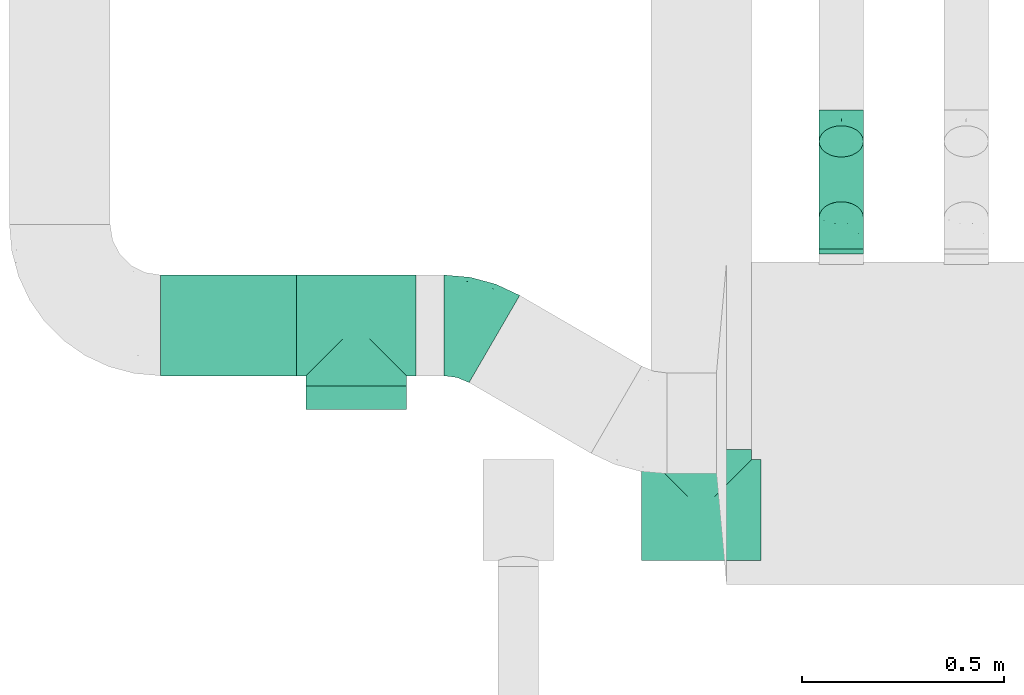
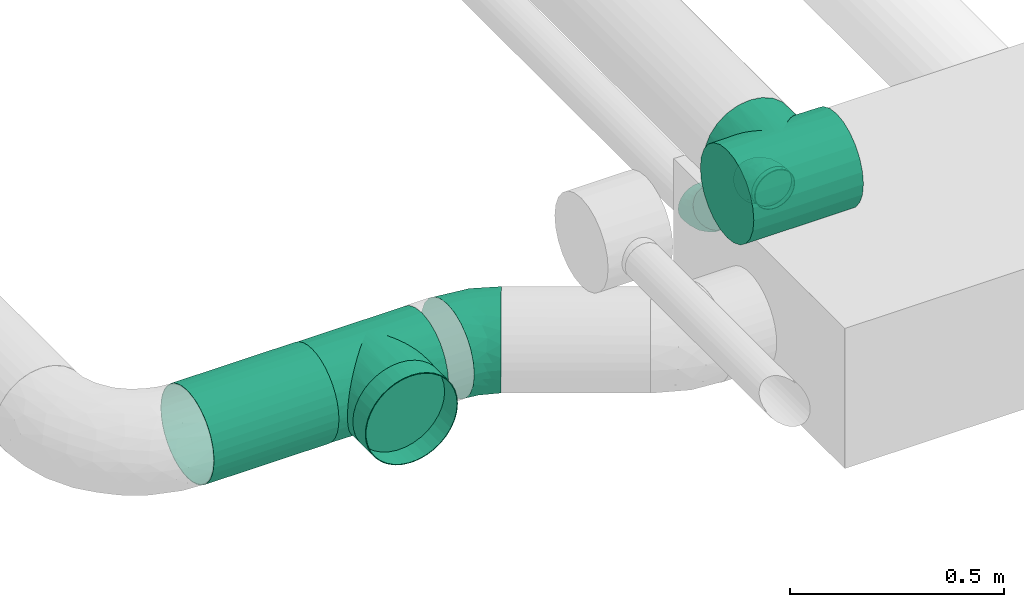
# One storey, part 18 of 91: 5 flow fittings, 4 flow segments.
"""IFC2X3 building model written with IfcOpenShell, lengths in millimetres."""

from ifc_helpers import new_model, entity, si_unit, converted_unit, derived_unit, direction, frame, origin_with_axes, origin_2d_with_axis, place, context, subcontext, project, spatial, hollow_circle, extrude, open_shell, surface_model, source, transform, mapped, material, layer, layer_set, layer_usage, type_object, element, save


model = new_model("IFC2X3")

# Units and contexts
model_context = context("Model", 3, precision=1e-05, world=origin_with_axes(), true_north=direction((0.0, 1.0)))
body_context = subcontext(model_context, "Body", "Model", "MODEL_VIEW")
ifc_project = project(units=[si_unit("AREAUNIT", "SQUARE_METRE"), si_unit("VOLUMEUNIT", "CUBIC_METRE", prefix="DECI"), si_unit("TIMEUNIT", "SECOND"), si_unit("THERMODYNAMICTEMPERATUREUNIT", "DEGREE_CELSIUS"), si_unit("PRESSUREUNIT", "PASCAL"), si_unit("MASSUNIT", "GRAM", prefix="KILO"), si_unit("LENGTHUNIT", "METRE", prefix="MILLI"), si_unit("POWERUNIT", "WATT"), si_unit("ELECTRICCURRENTUNIT", "AMPERE"), si_unit("ELECTRICVOLTAGEUNIT", "VOLT"), derived_unit("VOLUMETRICFLOWRATEUNIT", [(si_unit("VOLUMEUNIT", "CUBIC_METRE", prefix="DECI"), 1), (si_unit("TIMEUNIT", "SECOND"), -1)]), derived_unit("LINEARVELOCITYUNIT", [(si_unit("LENGTHUNIT", "METRE"), 1), (si_unit("TIMEUNIT", "SECOND"), -1)]), derived_unit("MASSDENSITYUNIT", [(si_unit("MASSUNIT", "GRAM", prefix="KILO"), 1), (si_unit("VOLUMEUNIT", "CUBIC_METRE"), -1)]), converted_unit("PLANEANGLEUNIT", "DEGREE", entity("IfcRatioMeasure", 0.01745), si_unit("PLANEANGLEUNIT", "RADIAN"), dimensions=[0, 0, 0, 0, 0, 0, 0])], contexts=[model_context])

# Site, building, storey
site_placement = place(None, origin_with_axes())
site = spatial("IfcSite", under=ifc_project, at=site_placement, CompositionType="ELEMENT")
building_placement = place(site_placement, origin_with_axes())
building = spatial("IfcBuilding", under=site, at=building_placement, Name="mc-building", CompositionType="ELEMENT")
storey_placement = place(building_placement, frame((0.0, 0.0, 8700.0), z_axis=(0.0, 0.0, 1.0), x_axis=(1.0, 0.0, 0.0)))
storey = spatial("IfcBuildingStorey", under=building, at=storey_placement, CompositionType="ELEMENT", Elevation=8700.0)

# Flow fittings
duct_fitting_type_1 = type_object("IfcDuctFittingType", PredefinedType="JUNCTION")
shared_shape_1 = source(origin_with_axes(), body_context, "Body", "SurfaceModel", [
    surface_model("IfcShellBasedSurfaceModel", [(0.0, -150.0, -125.0), (32.35238, -150.0, -120.74073), (-32.35238, -150.0, -120.74073), (-120.74073, -150.0, 32.35238), (-62.5, -150.0, -108.25318), (-88.38835, -150.0, -88.38835), (-108.25318, -150.0, -62.5), (125.0, -150.0, 0.0), (120.74073, -150.0, 32.35238), (88.38835, -150.0, -88.38835), (62.5, -150.0, -108.25318), (120.74073, -150.0, -32.35238), (108.25318, -150.0, -62.5), (-120.74073, -150.0, -32.35238), (-108.25318, -150.0, 62.5), (-88.38835, -150.0, 88.38835), (-62.5, -150.0, 108.25318), (-32.35238, -150.0, 120.74073), (0.0, -150.0, 125.0), (108.25318, -150.0, 62.5), (88.38835, -150.0, 88.38835), (32.35238, -150.0, 120.74073), (62.5, -150.0, 108.25318), (-125.0, -150.0, 0.0), (0.0, 0.0, 125.0), (-11.24036, -11.24036, 124.49359), (0.0, -97.5961, 125.0), (-33.53651, -33.53651, 120.4172), (-44.49198, -44.49198, 116.8138), (-22.43518, -22.43518, 122.97017), (-55.24206, -55.24206, 112.13079), (-65.71683, -65.71683, 106.33107), (-75.83315, -75.83315, 99.36968), (-102.85623, -102.85623, 71.03235), (-98.32076, -150.0, 75.44417), (-94.54916, -94.54916, 81.76463), (-85.4881, -85.4881, 91.19641), (-116.36385, -116.36385, 45.65581), (-114.49695, -150.0, 47.42619), (-121.04637, -121.04637, 31.18936), (-110.2104, -110.2104, 58.98025), (-123.99275, -123.99275, 15.83659), (-125.0, -125.0, 0.0), (-122.87036, -150.0, 16.17619), (-121.04637, -121.04637, -31.18936), (-116.36385, -116.36385, -45.65581), (-122.87036, -150.0, -16.17619), (-123.99275, -123.99275, -15.83659), (-11.24036, -11.24036, -124.49359), (0.0, 0.0, -125.0), (0.0, -97.5961, -125.0), (-94.54916, -94.54916, -81.76463), (-98.32076, -150.0, -75.44417), (-110.2104, -110.2104, -58.98025), (-102.85623, -102.85623, -71.03235), (-114.49695, -150.0, -47.42619), (-85.4881, -85.4881, -91.19641), (-44.49198, -44.49198, -116.8138), (-33.53651, -33.53651, -120.4172), (-55.24206, -55.24206, -112.13079), (-22.43518, -22.43518, -122.97017), (-75.83315, -75.83315, -99.36968), (-65.71683, -65.71683, -106.33107), (11.24036, -11.24036, -124.49359), (0.0, -97.59611, -125.0), (33.53651, -33.53651, -120.4172), (44.49198, -44.49198, -116.8138), (22.43518, -22.43518, -122.97017), (55.24206, -55.24206, -112.13079), (65.71683, -65.71683, -106.33107), (75.83315, -75.83315, -99.36968), (102.85623, -102.85623, -71.03235), (98.32076, -150.0, -75.44417), (94.54916, -94.54916, -81.76463), (85.4881, -85.4881, -91.19641), (116.36385, -116.36385, -45.65581), (114.49695, -150.0, -47.42619), (121.04637, -121.04637, -31.18936), (110.2104, -110.2104, -58.98025), (123.99275, -123.99275, -15.83659), (125.0, -125.0, 0.0), (122.87036, -150.0, -16.17619), (121.04637, -121.04637, 31.18936), (116.36385, -116.36385, 45.65581), (122.87036, -150.0, 16.17619), (123.99275, -123.99275, 15.83659), (11.24036, -11.24036, 124.49359), (94.54916, -94.54916, 81.76463), (98.32076, -150.0, 75.44417), (110.2104, -110.2104, 58.98025), (102.85623, -102.85623, 71.03235), (114.49695, -150.0, 47.42619), (85.4881, -85.4881, 91.19641), (44.49198, -44.49198, 116.8138), (33.53651, -33.53651, 120.4172), (55.24206, -55.24206, 112.13079), (22.43518, -22.43518, 122.97017), (75.83315, -75.83315, 99.36968), (65.71683, -65.71683, 106.33107), (-148.0, 0.0, -125.0), (-148.0, -32.35238, -120.74073), (-148.0, 32.35238, -120.74073), (-148.0, 120.74073, 32.35238), (-148.0, 62.5, -108.25318), (-148.0, 88.38835, -88.38835), (-148.0, 108.25318, -62.5), (-148.0, -125.0, 0.0), (-148.0, -120.74073, 32.35238), (-148.0, -88.38835, -88.38835), (-148.0, -62.5, -108.25318), (-148.0, -120.74073, -32.35238), (-148.0, -108.25318, -62.5), (-148.0, 120.74073, -32.35238), (-148.0, 108.25318, 62.5), (-148.0, 62.5, 108.25318), (-148.0, 32.35238, 120.74073), (-148.0, 88.38835, 88.38835), (-148.0, 0.0, 125.0), (-148.0, -108.25318, 62.5), (-148.0, -88.38835, 88.38835), (-148.0, -32.35238, 120.74073), (-148.0, -62.5, 108.25318), (-148.0, 125.0, 0.0), (148.0, 32.35238, -120.74073), (148.0, 125.0, 0.0), (148.0, 0.0, -125.0), (148.0, 62.5, -108.25318), (148.0, 108.25318, -62.5), (148.0, 88.38835, -88.38835), (148.0, -88.38835, -88.38835), (148.0, -120.74073, 32.35238), (148.0, -62.5, -108.25318), (148.0, -32.35238, -120.74073), (148.0, -108.25318, -62.5), (148.0, -120.74073, -32.35238), (148.0, -125.0, 0.0), (148.0, 120.74073, -32.35238), (148.0, 120.74073, 32.35238), (148.0, 108.25318, 62.5), (148.0, 62.5, 108.25318), (148.0, 32.35238, 120.74073), (148.0, 88.38835, 88.38835), (148.0, -62.5, 108.25318), (148.0, -108.25318, 62.5), (148.0, -88.38835, 88.38835), (148.0, -32.35238, 120.74073), (148.0, 0.0, 125.0), (-97.59611, 0.0, -125.0), (-148.0, -98.32076, -75.44417), (-148.0, -114.49695, -47.42619), (-148.0, -122.87036, -16.17619), (97.59611, 0.0, -125.0), (148.0, -98.32076, -75.44417), (148.0, -114.49695, -47.42619), (148.0, -122.87036, -16.17619), (-148.0, -122.87036, 16.17619), (-97.5961, 0.0, 125.0), (-148.0, -98.32076, 75.44417), (-148.0, -114.49695, 47.42619), (148.0, -114.49695, 47.42619), (148.0, -122.87036, 16.17619), (148.0, -98.32076, 75.44417), (97.59611, 0.0, 125.0)], [open_shell([[[0, 1, 2]], [[2, 3, 4]], [[5, 3, 6]], [[4, 3, 5]], [[2, 7, 8]], [[9, 7, 10]], [[2, 1, 10]], [[11, 7, 12]], [[9, 12, 7]], [[10, 7, 2]], [[13, 6, 3]], [[14, 3, 2]], [[2, 15, 14]], [[16, 2, 17]], [[16, 15, 2]], [[18, 17, 2]], [[8, 19, 2]], [[19, 20, 2]], [[21, 18, 22]], [[2, 20, 22]], [[18, 2, 22]], [[23, 13, 3]], [[24, 25, 26]], [[27, 28, 17]], [[29, 27, 17]], [[17, 26, 29]], [[17, 18, 26]], [[17, 28, 30]], [[17, 30, 16]], [[16, 31, 32]], [[31, 16, 30]], [[16, 32, 15]], [[29, 26, 25]], [[33, 34, 35]], [[36, 35, 15]], [[37, 3, 38]], [[33, 14, 34]], [[37, 39, 3]], [[37, 38, 40]], [[33, 40, 14]], [[38, 14, 40]], [[15, 35, 34]], [[41, 42, 23]], [[41, 23, 43]], [[43, 3, 39]], [[43, 39, 41]], [[36, 15, 32]], [[44, 45, 13]], [[44, 46, 47]], [[48, 49, 50]], [[51, 5, 52]], [[53, 54, 6]], [[53, 55, 45]], [[53, 6, 55]], [[23, 42, 47]], [[51, 52, 54]], [[23, 47, 46]], [[46, 44, 13]], [[13, 45, 55]], [[54, 52, 6]], [[51, 56, 5]], [[57, 58, 2]], [[59, 57, 2]], [[0, 2, 50]], [[48, 50, 60]], [[58, 60, 2]], [[61, 62, 4]], [[61, 4, 5]], [[59, 4, 62]], [[59, 2, 4]], [[50, 2, 60]], [[61, 5, 56]], [[49, 63, 64]], [[65, 66, 1]], [[67, 65, 1]], [[1, 64, 67]], [[1, 0, 64]], [[1, 66, 68]], [[1, 68, 10]], [[10, 69, 70]], [[69, 10, 68]], [[10, 70, 9]], [[67, 64, 63]], [[71, 72, 73]], [[74, 73, 9]], [[75, 11, 76]], [[71, 12, 72]], [[75, 77, 11]], [[75, 76, 78]], [[71, 78, 12]], [[76, 12, 78]], [[9, 73, 72]], [[79, 80, 7]], [[79, 7, 81]], [[81, 11, 77]], [[81, 77, 79]], [[74, 9, 70]], [[82, 83, 8]], [[82, 84, 85]], [[86, 24, 26]], [[87, 20, 88]], [[89, 90, 19]], [[89, 91, 83]], [[89, 19, 91]], [[80, 85, 7]], [[87, 88, 90]], [[7, 85, 84]], [[8, 84, 82]], [[83, 91, 8]], [[90, 88, 19]], [[87, 92, 20]], [[93, 94, 21]], [[95, 93, 21]], [[18, 21, 26]], [[86, 26, 96]], [[94, 96, 21]], [[97, 98, 22]], [[97, 22, 20]], [[95, 22, 98]], [[95, 21, 22]], [[26, 21, 96]], [[97, 20, 92]], [[99, 100, 101]], [[101, 102, 103]], [[104, 102, 105]], [[103, 102, 104]], [[101, 106, 107]], [[108, 106, 109]], [[101, 100, 109]], [[110, 106, 111]], [[108, 111, 106]], [[109, 106, 101]], [[112, 105, 102]], [[113, 102, 101]], [[114, 113, 101]], [[114, 101, 115]], [[116, 113, 114]], [[117, 115, 101]], [[107, 118, 101]], [[118, 119, 101]], [[120, 117, 121]], [[119, 121, 117]], [[101, 119, 117]], [[122, 112, 102]], [[123, 124, 125]], [[126, 124, 123]], [[127, 124, 128]], [[126, 128, 124]], [[129, 125, 130]], [[125, 129, 131]], [[131, 132, 125]], [[133, 130, 134]], [[129, 130, 133]], [[130, 135, 134]], [[124, 127, 136]], [[137, 138, 125]], [[125, 138, 139]], [[140, 125, 139]], [[139, 138, 141]], [[125, 140, 142]], [[125, 143, 130]], [[144, 143, 125]], [[144, 125, 142]], [[140, 145, 142]], [[140, 146, 145]], [[124, 137, 125]], [[24, 146, 140]], [[114, 140, 139]], [[117, 24, 115]], [[115, 24, 140]], [[140, 114, 115]], [[139, 116, 114]], [[113, 141, 138]], [[102, 138, 137]], [[122, 137, 124]], [[116, 141, 113]], [[113, 138, 102]], [[137, 122, 102]], [[141, 116, 139]], [[136, 127, 105]], [[124, 136, 112]], [[112, 122, 124]], [[105, 112, 136]], [[127, 104, 105]], [[127, 128, 104]], [[103, 128, 126]], [[101, 126, 123]], [[49, 123, 125]], [[103, 126, 101]], [[49, 99, 101]], [[123, 49, 101]], [[128, 103, 104]], [[49, 48, 147]], [[58, 57, 100]], [[60, 58, 100]], [[100, 147, 60]], [[100, 99, 147]], [[100, 57, 59]], [[100, 59, 109]], [[109, 62, 61]], [[62, 109, 59]], [[109, 61, 108]], [[60, 147, 48]], [[54, 148, 51]], [[56, 51, 108]], [[45, 110, 149]], [[54, 111, 148]], [[45, 44, 110]], [[45, 149, 53]], [[54, 53, 111]], [[149, 111, 53]], [[108, 51, 148]], [[47, 42, 106]], [[47, 106, 150]], [[150, 110, 44]], [[150, 44, 47]], [[56, 108, 61]], [[151, 132, 67]], [[131, 70, 69]], [[70, 131, 129]], [[132, 131, 68]], [[69, 68, 131]], [[125, 132, 151]], [[63, 151, 67]], [[66, 65, 132]], [[68, 66, 132]], [[67, 132, 65]], [[133, 71, 152]], [[134, 75, 153]], [[79, 135, 80]], [[135, 79, 154]], [[73, 152, 71]], [[77, 134, 154]], [[73, 74, 129]], [[73, 129, 152]], [[63, 49, 151]], [[78, 153, 75]], [[78, 133, 153]], [[77, 75, 134]], [[77, 154, 79]], [[71, 133, 78]], [[129, 74, 70]], [[39, 37, 107]], [[39, 155, 41]], [[25, 24, 156]], [[35, 119, 157]], [[40, 33, 118]], [[40, 158, 37]], [[40, 118, 158]], [[42, 41, 106]], [[35, 157, 33]], [[106, 41, 155]], [[107, 155, 39]], [[37, 158, 107]], [[33, 157, 118]], [[35, 36, 119]], [[28, 27, 120]], [[30, 28, 120]], [[117, 120, 156]], [[25, 156, 29]], [[27, 29, 120]], [[32, 31, 121]], [[32, 121, 119]], [[30, 121, 31]], [[30, 120, 121]], [[156, 120, 29]], [[32, 119, 36]], [[85, 80, 135]], [[159, 143, 89]], [[130, 82, 160]], [[161, 144, 87]], [[83, 130, 159]], [[85, 160, 82]], [[83, 82, 130]], [[90, 143, 161]], [[90, 89, 143]], [[90, 161, 87]], [[96, 162, 86]], [[159, 89, 83]], [[85, 135, 160]], [[144, 92, 87]], [[92, 144, 97]], [[98, 97, 142]], [[95, 142, 145]], [[142, 95, 98]], [[144, 142, 97]], [[145, 146, 162]], [[93, 95, 145]], [[94, 93, 145]], [[145, 162, 96]], [[24, 86, 162]], [[94, 145, 96]]])]),
])
for number, where, z_axis, x_axis in (
    (1, (8419.02679, 7675.18604, 1214.30701), (0.0, 0.0, 1.0), (-1.0, 0.0, 0.0)),
    (2, (7563.36286, 8133.41275, 668.0), (0.0, 0.0, 1.0), (1.0, 0.0, 0.0)),
):
    element("IfcFlowFitting", number, at=place(storey_placement, frame(where, z_axis=z_axis, x_axis=x_axis)), inside=storey, type_object=duct_fitting_type_1, context=body_context, shape_type="MappedRepresentation", body=[
        mapped(shared_shape_1, transform((0.0, 0.0, 0.0), scale=1.0)),
    ])

# Flow segment
ifc_material = material(Name="FZ1")
ifc_layer = layer(ifc_material, 0.0)
ifc_layer_set = layer_set([ifc_layer], Name="FZ1")
ifc_layer_usage = layer_usage(ifc_layer_set, "AXIS1", "POSITIVE", 0.0)
duct_segment_type_1 = type_object("IfcDuctSegmentType", PredefinedType="RIGIDSEGMENT")
shared_shape_2 = source(origin_with_axes(), body_context, "Body", "SweptSolid", [
    extrude(hollow_circle(Radius=55.0, WallThickness=2.0, at=origin_2d_with_axis()), frame((0.0, 0.0, 0.0), z_axis=(1.0, 0.0, 0.0), x_axis=(0.0, 1.0, 0.0)), (0.0, 0.0, 1.0), 266.7),
])
flow_segment_1_placement = place(storey_placement, frame((8766.57414, 8401.1274, 635.78175), z_axis=(0.0, 0.707107, 0.707107), x_axis=(0.0, 0.707107, -0.707107)))
element("IfcFlowSegment", 3, at=flow_segment_1_placement, inside=storey, type_object=duct_segment_type_1, material=ifc_layer_usage, context=body_context, shape_type="MappedRepresentation", body=[
    mapped(shared_shape_2, transform((0.0, 0.0, 0.0), scale=1.0)),
])

# Flow fittings
duct_fitting_type_2 = type_object("IfcDuctFittingType", Name="BU", PredefinedType="BEND")
shared_shape_3 = source(origin_with_axes(), body_context, "Body", "SurfaceModel", [
    surface_model("IfcShellBasedSurfaceModel", [(-45.56349, 0.0, -55.0), (-45.56349, -14.23505, -53.12592), (-45.56349, 14.23505, -53.12592), (-45.56349, 53.12592, 14.23505), (-45.56349, 27.5, -47.63139), (-45.56349, 38.89087, -38.89087), (-45.56349, 47.63139, -27.5), (-45.56349, -55.0, 0.0), (-45.56349, -53.12592, 14.23505), (-45.56349, -38.89087, -38.89087), (-45.56349, -27.5, -47.63139), (-45.56349, -53.12592, -14.23505), (-45.56349, -47.63139, -27.5), (-45.56349, 53.12592, -14.23505), (-45.56349, 47.63139, 27.5), (-45.56349, 38.89087, 38.89087), (-45.56349, -14.23505, 53.12592), (-45.56349, 27.5, 47.63139), (-45.56349, 14.23505, 53.12592), (-45.56349, -47.63139, 27.5), (-45.56349, -38.89087, 38.89087), (-45.56349, -27.5, 47.63139), (-45.56349, 0.0, 55.0), (-45.56349, 55.0, 0.0), (22.15256, 42.28395, -53.12592), (-6.67262, 71.10913, 0.0), (32.21826, 32.21826, -55.0), (12.77282, 51.66369, -47.63139), (-1.46223, 65.89874, -27.5), (4.71825, 59.71825, -38.89087), (59.71825, 4.71825, -38.89087), (69.78395, -5.34744, 14.23505), (51.66369, 12.77282, -47.63139), (42.28395, 22.15256, -53.12592), (65.89874, -1.46223, -27.5), (69.78395, -5.34744, -14.23505), (71.10913, -6.67262, 0.0), (-5.34744, 69.78395, -14.23505), (-5.34744, 69.78395, 14.23505), (-1.46223, 65.89874, 27.5), (4.71825, 59.71825, 38.89087), (32.21826, 32.21826, 55.0), (12.77282, 51.66369, 47.63139), (22.15256, 42.28395, 53.12592), (59.71825, 4.71825, 38.89087), (65.89874, -1.46223, 27.5), (42.28395, 22.15256, 53.12592), (51.66369, 12.77282, 47.63139), (-20.16649, 48.68621, 33.48188), (-26.97111, 35.77503, 43.63444), (-7.30443, 43.73336, 43.63444), (-17.0934, 3.74816, 55.0), (-18.00408, 15.44793, 53.78143), (-30.11707, 22.39897, 50.81337), (-7.49776, 55.63651, 33.48188), (-15.97018, 58.74288, 21.04759), (-31.18231, 52.58712, 21.04759), (-18.35174, 61.03934, 10.51509), (-28.67677, 56.60048, 10.47121), (-34.03924, 44.64267, 33.48188), (-11.52288, 27.81868, 50.81338), (1.19951, 23.16465, 53.81115), (-33.77926, 57.34403, 0.0), (5.4586, 37.12132, 50.81809), (-24.5159, 59.18663, 0.0), (-16.66281, 64.4339, 0.0), (9.43651, 14.73721, 55.0), (-6.22531, 44.36822, -43.63444), (5.4586, 37.12132, -50.81809), (-34.03924, 44.64267, -33.48188), (9.43651, 14.73721, -55.0), (-17.0934, 3.74816, -55.0), (1.19951, 23.16465, -53.81115), (-11.52288, 27.81868, -50.81338), (-30.11707, 22.39897, -50.81337), (-25.75914, 36.08917, -43.63444), (-30.24487, 52.83011, -21.04759), (-20.16649, 48.68621, -33.48188), (-7.49776, 55.63651, -33.48188), (-18.00408, 15.44793, -53.78143), (-28.68366, 56.62226, -10.35271), (-14.15883, 63.53074, -10.87592), (-15.13548, 59.23394, -21.04759), (3.19797, -7.72059, -52.16847), (3.1272, -18.04126, -47.9241), (13.63233, -32.91136, -32.06475), (45.23618, -22.99734, -20.4997), (16.67434, -40.25541, -15.9539), (-17.3935, -51.68264, -9.80849), (-2.85835, -49.37776, 0.0), (48.84421, -24.24609, -9.80849), (-16.38424, -42.76862, -30.85433), (-6.97383, -29.41689, -42.70541), (41.82739, -18.65658, -30.85433), (-15.72523, -48.24839, -20.4997), (29.28945, -13.63928, -42.80781), (26.81493, -3.56603, -49.15704), (36.93651, -32.89419, 0.0), (-15.72523, -48.24839, 20.4997), (-17.3935, -51.68264, 9.80849), (-16.38424, -42.76862, 30.85433), (16.67434, -40.25541, 15.9539), (3.19797, -7.72059, 52.16847), (10.54583, -14.96836, 47.9241), (13.63233, -32.91136, 32.06475), (45.23618, -22.99734, 20.4997), (41.82739, -18.65658, 30.85433), (-11.06635, -30.3552, 42.80781), (25.73213, -15.86964, 42.70541), (-16.43945, -21.48258, 49.15704), (48.84421, -24.24609, 9.80849)], [open_shell([[[0, 1, 2]], [[2, 3, 4]], [[5, 3, 6]], [[4, 3, 5]], [[2, 7, 8]], [[9, 7, 10]], [[1, 10, 7]], [[11, 7, 12]], [[9, 12, 7]], [[7, 2, 1]], [[13, 6, 3]], [[14, 3, 2]], [[15, 14, 2]], [[16, 17, 2]], [[2, 17, 15]], [[16, 18, 17]], [[19, 20, 2]], [[19, 2, 8]], [[20, 21, 2]], [[2, 21, 16]], [[16, 22, 18]], [[23, 13, 3]], [[24, 25, 26]], [[27, 25, 24]], [[28, 25, 29]], [[29, 25, 27]], [[30, 26, 31]], [[26, 30, 32]], [[32, 33, 26]], [[34, 31, 35]], [[31, 34, 30]], [[35, 31, 36]], [[37, 25, 28]], [[26, 38, 39]], [[26, 39, 40]], [[41, 40, 42]], [[26, 40, 41]], [[42, 43, 41]], [[26, 44, 45]], [[31, 26, 45]], [[46, 47, 26]], [[47, 44, 26]], [[46, 26, 41]], [[26, 25, 38]], [[48, 49, 50]], [[22, 51, 52]], [[17, 49, 15]], [[53, 17, 18]], [[49, 17, 53]], [[54, 50, 40]], [[48, 55, 56]], [[55, 57, 58]], [[59, 14, 15]], [[60, 53, 52]], [[50, 49, 60]], [[58, 3, 56]], [[52, 51, 61]], [[62, 23, 3]], [[63, 50, 60]], [[50, 42, 40]], [[3, 58, 62]], [[43, 61, 41]], [[62, 58, 64]], [[48, 59, 49]], [[14, 56, 3]], [[40, 39, 54]], [[57, 64, 58]], [[39, 38, 55]], [[63, 60, 61]], [[54, 55, 48]], [[65, 57, 38]], [[56, 14, 59]], [[38, 25, 65]], [[60, 52, 61]], [[49, 59, 15]], [[55, 58, 56]], [[56, 59, 48]], [[55, 54, 39]], [[50, 54, 48]], [[18, 22, 52]], [[49, 53, 60]], [[18, 52, 53]], [[61, 51, 66]], [[41, 61, 66]], [[63, 61, 43]], [[43, 42, 63]], [[50, 63, 42]], [[38, 57, 55]], [[64, 57, 65]], [[67, 27, 68]], [[69, 5, 6]], [[70, 71, 72]], [[73, 74, 75]], [[76, 77, 69]], [[29, 78, 28]], [[2, 79, 0]], [[13, 23, 62]], [[2, 74, 79]], [[5, 75, 4]], [[77, 78, 67]], [[13, 62, 80]], [[64, 80, 62]], [[81, 80, 64]], [[67, 73, 75]], [[82, 77, 76]], [[81, 64, 65]], [[76, 69, 6]], [[82, 76, 80]], [[24, 72, 68]], [[74, 2, 4]], [[27, 67, 29]], [[26, 70, 72]], [[69, 75, 5]], [[82, 28, 78]], [[72, 71, 79]], [[6, 13, 76]], [[77, 67, 75]], [[13, 80, 76]], [[82, 37, 28]], [[81, 25, 37]], [[82, 81, 37]], [[75, 69, 77]], [[67, 78, 29]], [[82, 78, 77]], [[75, 74, 4]], [[79, 74, 73]], [[79, 73, 72]], [[79, 71, 0]], [[68, 72, 73]], [[26, 72, 24]], [[67, 68, 73]], [[27, 24, 68]], [[80, 81, 82]], [[25, 81, 65]], [[1, 83, 84]], [[85, 86, 87]], [[0, 71, 1]], [[88, 87, 89]], [[90, 86, 35]], [[91, 92, 85]], [[11, 88, 7]], [[30, 34, 93]], [[11, 12, 94]], [[92, 91, 9]], [[85, 94, 91]], [[94, 85, 87]], [[95, 93, 85]], [[85, 92, 95]], [[83, 71, 70]], [[12, 9, 91]], [[70, 26, 33]], [[96, 84, 83]], [[1, 71, 83]], [[95, 96, 32]], [[95, 30, 93]], [[95, 32, 30]], [[97, 89, 87]], [[34, 86, 93]], [[36, 97, 90]], [[94, 88, 11]], [[34, 35, 86]], [[90, 87, 86]], [[93, 86, 85]], [[32, 96, 33]], [[84, 10, 1]], [[33, 83, 70]], [[94, 12, 91]], [[10, 92, 9]], [[87, 88, 94]], [[7, 88, 89]], [[36, 90, 35]], [[87, 90, 97]], [[84, 95, 92]], [[33, 96, 83]], [[95, 84, 96]], [[10, 84, 92]], [[8, 98, 19]], [[7, 89, 99]], [[19, 98, 100]], [[101, 98, 99]], [[46, 102, 103]], [[104, 105, 106]], [[100, 98, 104]], [[107, 104, 108]], [[16, 51, 22]], [[51, 16, 102]], [[107, 20, 100]], [[107, 109, 21]], [[21, 20, 107]], [[103, 47, 46]], [[101, 89, 97]], [[105, 110, 31]], [[44, 47, 108]], [[105, 104, 101]], [[107, 100, 104]], [[31, 110, 36]], [[109, 16, 21]], [[108, 106, 44]], [[105, 45, 106]], [[41, 66, 46]], [[102, 66, 51]], [[46, 66, 102]], [[104, 98, 101]], [[99, 98, 8]], [[106, 108, 104]], [[110, 101, 97]], [[45, 44, 106]], [[105, 31, 45]], [[20, 19, 100]], [[109, 103, 102]], [[101, 110, 105]], [[36, 110, 97]], [[7, 99, 8]], [[101, 99, 89]], [[103, 107, 108]], [[16, 109, 102]], [[107, 103, 109]], [[47, 103, 108]]])]),
])
for number, where, z_axis, x_axis, name in (
    (4, (8766.57414, 8368.90914, 668.0), (1.0, 0.0, 0.0), (0.0, -0.707107, 0.707107), "BU"),
    (5, (8766.57414, 8621.90914, 415.0), (-1.0, 0.0, 0.0), (0.0, -1.0, 0.0), "BU"),
):
    element("IfcFlowFitting", number, at=place(storey_placement, frame(where, z_axis=z_axis, x_axis=x_axis)), inside=storey, type_object=duct_fitting_type_2, Name=name, context=body_context, shape_type="MappedRepresentation", body=[
        mapped(shared_shape_3, transform((0.0, 0.0, 0.0), scale=1.0)),
    ])

# Flow segment
shared_shape_4 = source(origin_with_axes(), body_context, "Body", "SweptSolid", [
    extrude(hollow_circle(Radius=55.0, WallThickness=2.0, at=origin_2d_with_axis()), frame((0.0, 0.0, 0.0), z_axis=(1.0, 0.0, 0.0), x_axis=(0.0, 1.0, 0.0)), (0.0, 0.0, 1.0), 13.0),
])
flow_segment_2_placement = place(storey_placement, frame((8766.57414, 8310.34565, 668.0), z_axis=(0.0, 0.0, 1.0), x_axis=(0.0, 1.0, 0.0)))
element("IfcFlowSegment", 6, at=flow_segment_2_placement, inside=storey, type_object=duct_segment_type_1, material=ifc_layer_usage, context=body_context, shape_type="MappedRepresentation", body=[
    mapped(shared_shape_4, transform((0.0, 0.0, 0.0), scale=1.0, scale2=1.0, scale3=1.0, uniform=False)),
])

# Flow fitting
shared_shape_5 = source(origin_with_axes(), body_context, "Body", "SurfaceModel", [
    surface_model("IfcShellBasedSurfaceModel", [(-67.28726, 0.0, -125.0), (-67.28726, -32.35238, -120.74073), (-67.28726, 32.35238, -120.74073), (-67.28726, 120.74073, 32.35238), (-67.28726, 62.5, -108.25318), (-67.28726, 108.25318, -62.5), (-67.28726, 88.38835, -88.38835), (-67.28726, -125.0, 0.0), (-67.28726, -120.74073, 32.35238), (-67.28726, -88.38835, -88.38835), (-67.28726, -62.5, -108.25318), (-67.28726, -120.74073, -32.35238), (-67.28726, -108.25318, -62.5), (-67.28726, 120.74073, -32.35238), (-67.28726, 108.25318, 62.5), (-67.28726, 88.38835, 88.38835), (-67.28726, 32.35238, 120.74073), (-67.28726, 62.5, 108.25318), (-67.28726, 0.0, 125.0), (-67.28726, -108.25318, 62.5), (-67.28726, -88.38835, 88.38835), (-67.28726, -32.35238, 120.74073), (-67.28726, -62.5, 108.25318), (-67.28726, 125.0, 0.0), (41.95816, 61.75568, -120.74073), (-4.54512, 141.88699, 0.0), (58.19702, 33.77397, -125.0), (26.82595, 87.83048, -108.25318), (13.83163, 110.22142, -88.38835), (3.86074, 127.40259, -62.5), (102.56242, -42.67347, -88.38835), (118.80128, -70.65518, 32.35238), (89.5681, -20.28253, -108.25318), (74.43589, 5.79227, -120.74073), (112.53331, -59.85465, -62.5), (118.80128, -70.65518, -32.35238), (120.93917, -74.33904, 0.0), (-2.40723, 138.20313, -32.35238), (-2.40723, 138.20313, 32.35238), (3.86074, 127.40259, 62.5), (13.83163, 110.22142, 88.38835), (26.82595, 87.83048, 108.25318), (41.95816, 61.75568, 120.74073), (102.56242, -42.67347, 88.38835), (112.53331, -59.85465, 62.5), (89.5681, -20.28253, 108.25318), (74.43589, 5.79227, 120.74073), (58.19702, 33.77397, 125.0), (2.7391, 65.72477, 113.2695), (-31.8085, 59.10588, 111.83577), (-11.02899, 40.97728, 120.41659), (-23.69154, 3.83052, 125.0), (-22.08941, 82.07131, 99.16917), (-32.32681, 120.10748, 47.83543), (-35.40677, 102.5769, 76.09517), (-47.13657, 124.91618, 20.52456), (18.56823, 15.20469, 125.0), (-24.79608, 129.89284, 24.38629), (-34.79977, 129.29555, 0.0), (-44.73771, 124.83011, -23.26878), (-28.08634, 104.35239, -76.09517), (-13.76184, 84.53725, -99.16917), (-38.85537, 118.52404, -47.83543), (-11.02899, 40.97728, -120.41659), (-0.36968, 66.57614, -112.37151), (-23.69154, 3.83052, -125.0), (-34.58941, 56.24486, -112.96988), (-22.40853, 131.40134, -21.17123), (18.56823, 15.20469, -125.0), (10.72915, -39.86321, -114.48624), (23.74355, -88.21712, -74.66097), (-8.41227, -108.78488, -52.19026), (4.18859, -15.56234, -122.47183), (54.47512, -91.21914, -54.91056), (29.00263, -107.75676, -33.27987), (27.92352, -63.50076, -97.96461), (-1.89368, -119.25422, 0.0), (61.49597, -102.19296, 0.0), (-1.32948, -106.2389, 54.91056), (23.74355, -88.21712, 74.66097), (29.00263, -107.75676, 33.27987), (10.72915, -39.86321, 114.48624), (4.18859, -15.56234, 122.47183), (7.72222, -68.93793, 97.96461), (61.87897, -89.86605, 52.19026)], [open_shell([[[0, 1, 2]], [[2, 3, 4]], [[5, 6, 3]], [[3, 6, 4]], [[2, 7, 8]], [[9, 7, 10]], [[2, 1, 10]], [[11, 7, 12]], [[9, 12, 7]], [[10, 7, 2]], [[13, 5, 3]], [[14, 3, 2]], [[14, 2, 15]], [[2, 16, 17]], [[17, 15, 2]], [[16, 2, 18]], [[19, 20, 2]], [[2, 8, 19]], [[21, 18, 22]], [[20, 22, 18]], [[18, 2, 20]], [[23, 13, 3]], [[24, 25, 26]], [[27, 25, 24]], [[25, 28, 29]], [[27, 28, 25]], [[30, 26, 31]], [[26, 30, 32]], [[32, 33, 26]], [[30, 31, 34]], [[35, 34, 31]], [[35, 31, 36]], [[37, 25, 29]], [[38, 39, 26]], [[39, 40, 26]], [[41, 42, 26]], [[26, 40, 41]], [[43, 26, 42]], [[26, 44, 31]], [[43, 44, 26]], [[42, 45, 43]], [[42, 46, 45]], [[47, 46, 42]], [[38, 26, 25]], [[48, 49, 50]], [[16, 18, 51]], [[15, 17, 52]], [[49, 16, 50]], [[16, 49, 17]], [[39, 38, 53]], [[54, 14, 15]], [[15, 52, 54]], [[53, 14, 54]], [[49, 52, 17]], [[41, 48, 42]], [[55, 23, 3]], [[51, 56, 50]], [[55, 57, 58]], [[54, 39, 53]], [[51, 50, 16]], [[52, 48, 41]], [[47, 42, 56]], [[25, 57, 38]], [[57, 53, 38]], [[53, 3, 14]], [[39, 54, 40]], [[25, 58, 57]], [[52, 49, 48]], [[40, 54, 52]], [[57, 55, 53]], [[40, 52, 41]], [[42, 48, 50]], [[53, 55, 3]], [[42, 50, 56]], [[23, 55, 58]], [[23, 59, 13]], [[60, 6, 5]], [[28, 60, 29]], [[61, 6, 60]], [[5, 62, 60]], [[24, 63, 64]], [[0, 2, 65]], [[24, 64, 27]], [[63, 65, 2]], [[61, 64, 66]], [[29, 62, 37]], [[64, 61, 27]], [[23, 58, 59]], [[61, 28, 27]], [[29, 60, 62]], [[6, 61, 4]], [[37, 67, 25]], [[62, 67, 37]], [[62, 5, 13]], [[68, 63, 24]], [[61, 60, 28]], [[24, 26, 68]], [[59, 62, 13]], [[25, 67, 58]], [[65, 63, 68]], [[66, 2, 4]], [[67, 59, 58]], [[2, 66, 63]], [[59, 67, 62]], [[61, 66, 4]], [[66, 64, 63]], [[69, 10, 1]], [[70, 71, 12]], [[65, 72, 0]], [[71, 73, 74]], [[11, 71, 74]], [[75, 9, 10]], [[7, 11, 76]], [[77, 74, 35]], [[9, 70, 12]], [[74, 76, 11]], [[70, 73, 71]], [[72, 65, 68]], [[26, 33, 72]], [[9, 75, 70]], [[69, 33, 32]], [[1, 72, 69]], [[30, 70, 75]], [[69, 32, 75]], [[74, 73, 35]], [[30, 34, 70]], [[35, 36, 77]], [[0, 72, 1]], [[73, 70, 34]], [[74, 77, 76]], [[32, 30, 75]], [[12, 71, 11]], [[72, 68, 26]], [[69, 72, 33]], [[35, 73, 34]], [[10, 69, 75]], [[78, 79, 19]], [[8, 7, 76]], [[20, 19, 79]], [[80, 8, 76]], [[8, 80, 78]], [[43, 79, 44]], [[46, 81, 45]], [[81, 21, 22]], [[82, 18, 21]], [[21, 81, 82]], [[20, 79, 83]], [[46, 82, 81]], [[83, 81, 22]], [[82, 51, 18]], [[77, 80, 76]], [[22, 20, 83]], [[45, 81, 83]], [[78, 84, 79]], [[36, 31, 77]], [[84, 31, 44]], [[8, 78, 19]], [[56, 82, 47]], [[82, 56, 51]], [[46, 47, 82]], [[79, 84, 44]], [[31, 84, 80]], [[45, 83, 43]], [[84, 78, 80]], [[31, 80, 77]], [[43, 83, 79]]])]),
])
flow_fitting_placement = place(storey_placement, frame((7848.023, 8133.41275, 668.0), z_axis=(0.0, 0.0, 1.0), x_axis=(-0.864904, 0.501937, 0.0)))
element("IfcFlowFitting", 7, at=flow_fitting_placement, inside=storey, type_object=duct_fitting_type_2, Name="BU", context=body_context, shape_type="MappedRepresentation", body=[
    mapped(shared_shape_5, transform((0.0, 0.0, 0.0), scale=1.0)),
])

# Flow segments
duct_segment_type_2 = type_object("IfcDuctSegmentType", Name="Safe", PredefinedType="RIGIDSEGMENT")
shared_shape_6 = source(origin_with_axes(), body_context, "Body", "SweptSolid", [
    extrude(hollow_circle(Radius=125.0, WallThickness=2.0, at=origin_2d_with_axis()), frame((0.0, 0.0, 0.0), z_axis=(1.0, 0.0, 0.0), x_axis=(0.0, 1.0, 0.0)), (0.0, 0.0, 1.0), 58.2),
])
flow_segment_3_placement = place(storey_placement, frame((7563.36286, 7983.41275, 668.0), z_axis=(0.0, 0.0, 1.0), x_axis=(0.0, -1.0, 0.0)))
element("IfcFlowSegment", 8, at=flow_segment_3_placement, inside=storey, type_object=duct_segment_type_2, material=ifc_layer_usage, Name="Safe", context=body_context, shape_type="MappedRepresentation", body=[
    mapped(shared_shape_6, transform((0.0, 0.0, 0.0), scale=1.0)),
])
shared_shape_7 = source(origin_with_axes(), body_context, "Body", "SweptSolid", [
    extrude(hollow_circle(Radius=125.0, WallThickness=2.0, at=origin_2d_with_axis()), frame((0.0, 0.0, 0.0), z_axis=(1.0, 0.0, 0.0), x_axis=(0.0, 1.0, 0.0)), (0.0, 0.0, 1.0), 337.3),
])
flow_segment_4_placement = place(storey_placement, frame((7078.023, 8133.41275, 668.0), z_axis=(0.0, 0.0, 1.0), x_axis=(1.0, 0.0, 0.0)))
element("IfcFlowSegment", 9, at=flow_segment_4_placement, inside=storey, type_object=duct_segment_type_2, material=ifc_layer_usage, Name="Safe", context=body_context, shape_type="MappedRepresentation", body=[
    mapped(shared_shape_7, transform((0.0, 0.0, 0.0), scale=1.0)),
])

save(model, "model.ifc")
